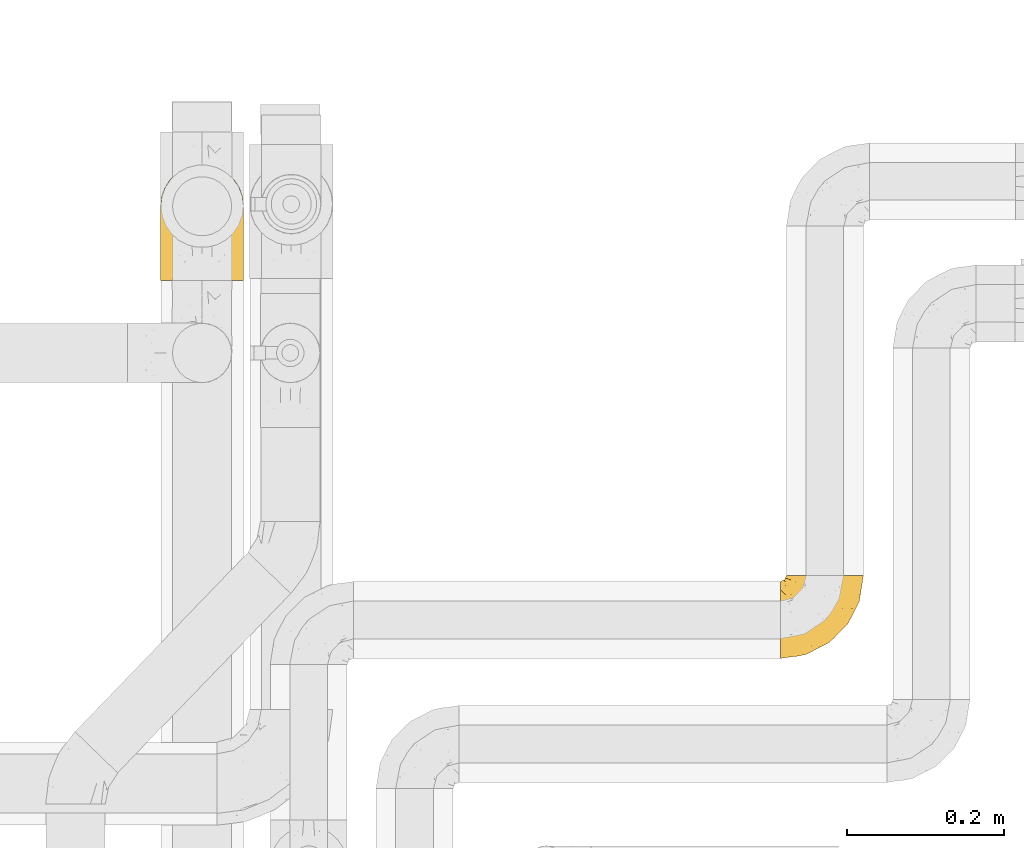
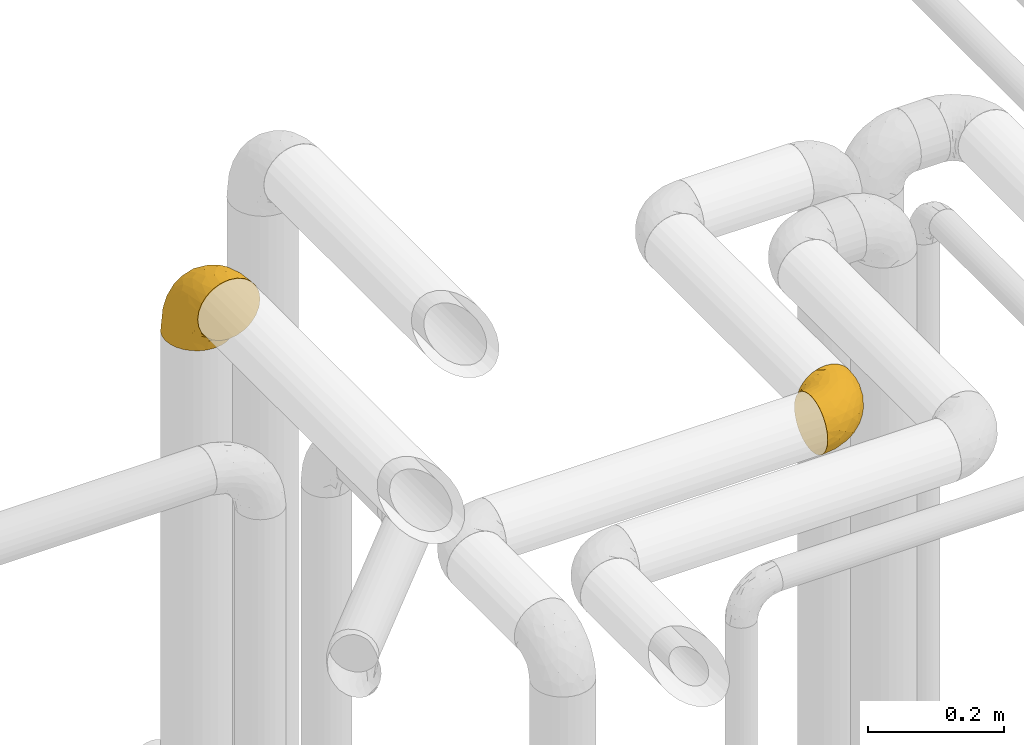
# One storey, part 397 of 827: 2 coverings.
"""IFC2X3 building model written with IfcOpenShell, lengths in millimetres."""

import ifcopenshell
import ifcopenshell.guid

model = None  # the IFC model being written
_history = None  # IfcOwnerHistory: only IFC2X3 demands one
_inside = {}  # id of a spatial element -> (the spatial element, [elements in it])
_under = {}  # id of a project, library or spatial element -> (it, [spatial elements below it])
_declared = {}  # id of a project -> (the project, [libraries it declares])
_typed = {}  # id of a type object -> (the type object, [elements of that type])
_made_of = {}  # id of a material, layer set ... -> (it, [elements and type objects made of it])


def new_model(schema):
    """Start an empty IFC model of exactly this schema.

    Asked for "IFC4X3", IfcOpenShell would pick the latest addendum, in which some entities
    have other attributes; the version numbers below select the first issue.
    IFC2X3 requires an IfcOwnerHistory on every rooted entity: one is made here for all.
    """
    global model, _history
    if schema == "IFC4X3":
        model = ifcopenshell.file(schema_version=(4, 3, 0, 0))
    else:
        model = ifcopenshell.file(schema=schema)
    _inside.clear()
    _under.clear()
    _declared.clear()
    _typed.clear()
    _made_of.clear()
    _history = None
    if model.schema == "IFC2X3":
        org = make("IfcOrganization", Name="unknown")
        user = make(
            "IfcPersonAndOrganization",
            ThePerson=make("IfcPerson", FamilyName="unknown"),
            TheOrganization=org,
        )
        app = make(
            "IfcApplication",
            ApplicationDeveloper=org,
            Version="unknown",
            ApplicationFullName="unknown",
            ApplicationIdentifier="unknown",
        )
        _history = make(
            "IfcOwnerHistory",
            OwningUser=user,
            OwningApplication=app,
            ChangeAction="ADDED",
            CreationDate=0,
        )
    return model


def make(cls, **values):
    """One entity of the class cls with the attributes given. An attribute that is None is left unset."""
    return model.create_entity(
        cls, **{name: value for name, value in values.items() if value is not None}
    )


def entity(cls, *values):
    """Any entity or typed value of the class cls, its attributes in the order of the schema. None: left unset."""
    e = model.create_entity(cls)
    for i, value in enumerate(values):
        if value is not None:
            e[i] = value
    return e


def rooted(cls, **values):
    """An entity with a GlobalId (a new one), such as an element, a storey or a relation."""
    return make(cls, GlobalId=ifcopenshell.guid.new(), OwnerHistory=_history, **values)


def si_unit(unit_type, name, prefix=None):
    """IfcSIUnit, for example si_unit("LENGTHUNIT", "METRE", prefix="MILLI")."""
    return make("IfcSIUnit", UnitType=unit_type, Prefix=prefix, Name=name)


def converted_unit(unit_type, name, factor, base, dimensions=None, offset=None):
    """IfcConversionBasedUnit, such as the inch: factor (a typed value) times the base unit."""
    return make(
        "IfcConversionBasedUnit"
        if offset is None
        else "IfcConversionBasedUnitWithOffset",
        ConversionOffset=offset,
        Dimensions=None
        if dimensions is None
        else entity("IfcDimensionalExponents", *dimensions),
        UnitType=unit_type,
        Name=name,
        ConversionFactor=make(
            "IfcMeasureWithUnit", ValueComponent=factor, UnitComponent=base
        ),
    )


def derived_unit(unit_type, elements):
    """IfcDerivedUnit: a product of units, each with its exponent."""
    return make(
        "IfcDerivedUnit",
        Elements=[
            make("IfcDerivedUnitElement", Unit=unit, Exponent=power)
            for unit, power in elements
        ],
        UnitType=unit_type,
    )


def assignment(units):
    """IfcUnitAssignment: the units of a project."""
    return None if units is None else make("IfcUnitAssignment", Units=units)


def point(xyz):
    """IfcCartesianPoint."""
    return None if xyz is None else make("IfcCartesianPoint", Coordinates=xyz)


def direction(xyz):
    """IfcDirection."""
    return None if xyz is None else make("IfcDirection", DirectionRatios=xyz)


def frame(location, z_axis=None, x_axis=None):
    """IfcAxis2Placement3D, a coordinate frame: its origin and axes. An axis left out is left unset."""
    return make(
        "IfcAxis2Placement3D",
        Location=point(location),
        Axis=direction(z_axis),
        RefDirection=direction(x_axis),
    )


def origin():
    """The frame at (0, 0, 0) with its axes left unset."""
    return frame((0.0, 0.0, 0.0))


def place(relative_to, where):
    """IfcLocalPlacement: puts the frame where relative to a parent placement (None: the world)."""
    return make(
        "IfcLocalPlacement", PlacementRelTo=relative_to, RelativePlacement=where
    )


def context(
    kind, dimensions, precision=None, world=None, true_north=None, identifier=None
):
    """IfcGeometricRepresentationContext, for example the 3D "Model" context."""
    return make(
        "IfcGeometricRepresentationContext",
        ContextIdentifier=identifier,
        ContextType=kind,
        CoordinateSpaceDimension=dimensions,
        Precision=precision,
        WorldCoordinateSystem=world,
        TrueNorth=true_north,
    )


def subcontext(parent, identifier, kind, view, scale=None):
    """IfcGeometricRepresentationSubContext, for example "Body" below "Model"."""
    return make(
        "IfcGeometricRepresentationSubContext",
        ContextIdentifier=identifier,
        ContextType=kind,
        ParentContext=parent,
        TargetScale=scale,
        TargetView=view,
    )


def project(units=None, contexts=None):
    """IfcProject with its units and contexts."""
    return rooted(
        "IfcProject",
        Name="project",
        RepresentationContexts=contexts,
        UnitsInContext=assignment(units),
    )


def spatial(cls, under=None, at=None, **own):
    """A site, building, storey or space (cls), placed at a placement, below another one or the project."""
    s = rooted(cls, ObjectPlacement=at, **own)
    if under is not None:
        _under.setdefault(under.id(), (under, []))[1].append(s)
    return s


def faces_of(points, faces, orient=None, outer=None):
    """IfcFace entities. A face is a list of loops; a loop is a list of indices into points, from 0.

    orient and outer hold one flag for each loop. By default every Orientation is true, the
    first loop of a face is its IfcFaceOuterBound and the others are IfcFaceBound.
    """
    made = []
    for i, loops in enumerate(faces):
        bounds = []
        for j, loop in enumerate(loops):
            is_outer = j == 0 if outer is None else outer[i][j]
            bounds.append(
                make(
                    "IfcFaceOuterBound" if is_outer else "IfcFaceBound",
                    Bound=make("IfcPolyLoop", Polygon=[points[k] for k in loop]),
                    Orientation=True if orient is None else orient[i][j],
                )
            )
        made.append(make("IfcFace", Bounds=bounds))
    return made


def faceted_brep(points, faces, orient=None, outer=None, voids=None):
    """IfcFacetedBrep: a solid bounded by flat faces; with voids (closed shells), ...WithVoids."""
    shared = [point(p) for p in points]
    hull = make("IfcClosedShell", CfsFaces=faces_of(shared, faces, orient, outer))
    if voids is None:
        return make("IfcFacetedBrep", Outer=hull)
    return make(
        "IfcFacetedBrepWithVoids",
        Outer=hull,
        Voids=[
            make(cls, CfsFaces=faces_of(shared, fs, o, b)) for cls, fs, o, b in voids
        ],
    )


def shape(context_of_items, identifier, shape_type, items):
    """IfcShapeRepresentation: the items that make up one representation, for example the "Body"."""
    return make(
        "IfcShapeRepresentation",
        ContextOfItems=context_of_items,
        RepresentationIdentifier=identifier,
        RepresentationType=shape_type,
        Items=items,
    )


def made_of(thing, what):
    """Note that an element or type object is made of a material, layer set ...; save() writes the relation."""
    if what is not None:
        _made_of.setdefault(what.id(), (what, []))[1].append(thing)
    return thing


def element(
    cls,
    number,
    at=None,
    inside=None,
    cuts=None,
    type_object=None,
    material=None,
    context=None,
    identifier="Body",
    shape_type=None,
    held_by="IfcProductDefinitionShape",
    body=None,
    shapes=None,
    **own,
):
    """One element of the class cls, such as IfcWall. Its Tag is "e" and its number.

    at: its placement. inside: the storey or other place that contains it. cuts: it is an
    opening in that element (IfcRelVoidsElement). A single representation is given by context,
    identifier, shape_type and body (its items); several are given by shapes. held_by: the class
    of the entity that holds the representations. save() writes the other relations.
    """
    e = rooted(cls, Tag="e%d" % number, ObjectPlacement=at, **own)
    if body is not None:
        shapes = [shape(context, identifier, shape_type, body)]
    if shapes is not None:
        e.Representation = make(held_by, Representations=shapes)
    if inside is not None:
        _inside.setdefault(inside.id(), (inside, []))[1].append(e)
    if cuts is not None:
        rooted(
            "IfcRelVoidsElement", RelatingBuildingElement=cuts, RelatedOpeningElement=e
        )
    if type_object is not None:
        _typed.setdefault(type_object.id(), (type_object, []))[1].append(e)
    return made_of(e, material)


def aggregate(whole, parts):
    """IfcRelAggregates: a whole, such as a stair, and the parts it consists of."""
    return rooted("IfcRelAggregates", RelatingObject=whole, RelatedObjects=parts)


def save(model, path):
    """Write the relations noted so far, then the file.

    IfcRelAggregates (storeys below a building ...), IfcRelContainedInSpatialStructure (elements
    in a storey), IfcRelDefinesByType, IfcRelAssociatesMaterial and IfcRelDeclares: one each for
    every whole, place, type object, material and project.
    """
    for whole, parts in _under.values():
        aggregate(whole, parts)
    for where, things in _inside.values():
        rooted(
            "IfcRelContainedInSpatialStructure",
            RelatedElements=things,
            RelatingStructure=where,
        )
    for kind, things in _typed.values():
        rooted("IfcRelDefinesByType", RelatedObjects=things, RelatingType=kind)
    for what, things in _made_of.values():
        rooted("IfcRelAssociatesMaterial", RelatedObjects=things, RelatingMaterial=what)
    for by, libraries in _declared.values():
        rooted("IfcRelDeclares", RelatingContext=by, RelatedDefinitions=libraries)
    model.write(path)


model = new_model("IFC2X3")

# Units and contexts
model_context = context("Model", 3, precision=0.01, world=origin(), true_north=direction((6.12303176911189e-17, 1.0)))
body_context = subcontext(model_context, "Body", "Model", "MODEL_VIEW")
ifc_project = project(units=[si_unit("LENGTHUNIT", "METRE", prefix="MILLI"), si_unit("AREAUNIT", "SQUARE_METRE"), si_unit("VOLUMEUNIT", "CUBIC_METRE"), converted_unit("PLANEANGLEUNIT", "DEGREE", entity("IfcRatioMeasure", 0.0174532925199433), si_unit("PLANEANGLEUNIT", "RADIAN"), dimensions=[0, 0, 0, 0, 0, 0, 0]), si_unit("MASSUNIT", "GRAM", prefix="KILO"), derived_unit("MASSDENSITYUNIT", [(si_unit("MASSUNIT", "GRAM", prefix="KILO"), 1), (si_unit("LENGTHUNIT", "METRE"), -3)]), derived_unit("MOMENTOFINERTIAUNIT", [(si_unit("LENGTHUNIT", "METRE"), 4)]), si_unit("TIMEUNIT", "SECOND"), si_unit("FREQUENCYUNIT", "HERTZ"), si_unit("THERMODYNAMICTEMPERATUREUNIT", "DEGREE_CELSIUS"), derived_unit("THERMALTRANSMITTANCEUNIT", [(si_unit("MASSUNIT", "GRAM", prefix="KILO"), 1), (si_unit("THERMODYNAMICTEMPERATUREUNIT", "KELVIN"), -1), (si_unit("TIMEUNIT", "SECOND"), -3)]), derived_unit("VOLUMETRICFLOWRATEUNIT", [(si_unit("LENGTHUNIT", "METRE"), 3), (si_unit("TIMEUNIT", "SECOND"), -1)]), derived_unit("MASSFLOWRATEUNIT", [(si_unit("MASSUNIT", "GRAM", prefix="KILO"), 1), (si_unit("TIMEUNIT", "SECOND"), -1)]), derived_unit("ROTATIONALFREQUENCYUNIT", [(si_unit("TIMEUNIT", "SECOND"), -1)]), si_unit("ELECTRICCURRENTUNIT", "AMPERE"), si_unit("ELECTRICVOLTAGEUNIT", "VOLT"), si_unit("POWERUNIT", "WATT"), si_unit("FORCEUNIT", "NEWTON", prefix="KILO"), si_unit("ILLUMINANCEUNIT", "LUX"), si_unit("LUMINOUSFLUXUNIT", "LUMEN"), si_unit("LUMINOUSINTENSITYUNIT", "CANDELA"), derived_unit("USERDEFINED", [(si_unit("MASSUNIT", "GRAM", prefix="KILO"), -1), (si_unit("LENGTHUNIT", "METRE"), -2), (si_unit("TIMEUNIT", "SECOND"), 3), (si_unit("LUMINOUSFLUXUNIT", "LUMEN"), 1)]), derived_unit("LINEARVELOCITYUNIT", [(si_unit("LENGTHUNIT", "METRE"), 1), (si_unit("TIMEUNIT", "SECOND"), -1)]), si_unit("PRESSUREUNIT", "PASCAL"), derived_unit("USERDEFINED", [(si_unit("LENGTHUNIT", "METRE"), -2), (si_unit("MASSUNIT", "GRAM", prefix="KILO"), 1), (si_unit("TIMEUNIT", "SECOND"), -2)]), derived_unit("LINEARFORCEUNIT", [(si_unit("MASSUNIT", "GRAM", prefix="KILO"), 1), (si_unit("LENGTHUNIT", "METRE"), 1), (si_unit("TIMEUNIT", "SECOND"), -2), (si_unit("LENGTHUNIT", "METRE"), -1)]), derived_unit("PLANARFORCEUNIT", [(si_unit("MASSUNIT", "GRAM", prefix="KILO"), 1), (si_unit("LENGTHUNIT", "METRE"), 1), (si_unit("TIMEUNIT", "SECOND"), -2), (si_unit("LENGTHUNIT", "METRE"), -2)])], contexts=[model_context])

# Site, building, storey
site_placement = place(None, origin())
site = spatial("IfcSite", under=ifc_project, at=site_placement, CompositionType="ELEMENT")
building_placement = place(site_placement, origin())
building = spatial("IfcBuilding", under=site, at=building_placement, CompositionType="ELEMENT")
storey_placement = place(building_placement, frame((0.0, 0.0, 28200.0)))
storey = spatial("IfcBuildingStorey", under=building, at=storey_placement, Name="08", CompositionType="ELEMENT", Elevation=28200.0)

# Coverings
covering_1_placement = place(storey_placement, frame((47293.4, 14696.28, 2949.25)))
element("IfcCovering", 1, at=covering_1_placement, inside=storey, Name=":ADSK_", ObjectType=":ADSK_", PredefinedType="INSULATION", context=body_context, shape_type="Brep", body=[
    faceted_brep([(58.6, 107.75, 99.9), (69.54, 107.75, 98.66), (79.93, 107.75, 95.02), (89.25, 107.75, 89.17), (97.03, 107.75, 81.38), (102.88, 107.75, 72.06), (106.51, 107.75, 61.68), (107.75, 107.75, 50.75), (106.51, 107.75, 39.8), (102.87, 107.75, 29.41), (97.02, 107.75, 20.09), (89.23, 107.75, 12.31), (79.91, 107.75, 6.46), (69.53, 107.75, 2.83), (58.6, 107.75, 1.6), (52.89, 107.75, 2.24), (47.65, 107.75, 2.83), (42.46, 107.75, 4.65), (37.26, 107.75, 6.47), (27.94, 107.75, 12.32), (20.16, 107.75, 20.11), (14.31, 107.75, 29.43), (10.68, 107.75, 39.81), (9.45, 107.75, 50.75), (10.68, 107.75, 61.69), (14.32, 107.75, 72.08), (20.17, 107.75, 81.4), (27.96, 107.75, 89.18), (37.28, 107.75, 95.03), (42.47, 107.75, 96.85), (47.66, 107.75, 98.66), (52.89, 107.75, 99.25), (55.75, 107.75, 99.57), (1.6, 98.22, 38.02), (1.6, 93.31, 26.17), (1.6, 89.4, 21.08), (1.6, 85.5, 15.99), (1.6, 80.41, 12.09), (1.6, 75.32, 8.18), (1.6, 69.39, 5.73), (1.6, 63.47, 3.27), (1.6, 56.48, 2.35), (1.6, 53.61, 1.97), (1.6, 50.75, 1.6), (1.6, 38.02, 3.27), (1.6, 26.17, 8.18), (1.6, 15.99, 15.99), (1.6, 8.18, 26.17), (1.6, 3.27, 38.02), (1.6, 1.6, 50.75), (1.6, 3.27, 63.47), (1.6, 8.18, 75.32), (1.6, 15.99, 85.5), (1.6, 26.17, 93.31), (1.6, 38.02, 98.22), (1.6, 50.75, 99.9), (1.6, 56.48, 99.14), (1.6, 63.47, 98.22), (1.6, 69.39, 95.77), (1.6, 75.32, 93.31), (1.6, 80.41, 89.4), (1.6, 85.5, 85.5), (1.6, 89.4, 80.41), (1.6, 93.31, 75.32), (1.6, 98.22, 63.47), (1.6, 99.9, 50.75), (69.96, 27.53, 59.31), (59.59, 25.32, 73.08), (51.96, 16.29, 63.72), (34.4, 6.79, 50.75), (23.37, 4.51, 58.64), (13.68, 3.51, 50.75), (41.52, 17.47, 76.74), (26.26, 7.6, 67.68), (20.18, 12.27, 78.92), (72.33, 70.89, 94.31), (65.88, 87.17, 98.76), (57.55, 67.3, 98.4), (23.76, 31.65, 94.57), (46.5, 33.58, 89.91), (46.57, 47.23, 96.32), (21.17, 43.26, 98.79), (23.41, 55.08, 99.9), (17.92, 53.99, 99.9), (12.43, 52.9, 99.9), (9.72, 52.36, 99.9), (7.01, 51.82, 99.9), (26.77, 21.5, 87.31), (76.59, 89.94, 95.61), (95.55, 60.45, 60.43), (102.57, 83.0, 65.24), (92.89, 64.79, 72.87), (54.26, 85.93, 99.9), (51.17, 81.31, 99.9), (48.08, 76.69, 99.9), (44.99, 72.06, 99.9), (41.9, 67.44, 99.9), (85.16, 88.74, 90.65), (85.97, 45.98, 63.14), (59.58, 47.13, 91.89), (99.5, 89.4, 75.25), (105.83, 95.66, 50.75), (53.59, 28.5, 82.18), (67.0, 42.81, 85.08), (71.56, 38.28, 76.93), (87.47, 45.35, 50.75), (75.73, 33.61, 50.75), (92.24, 82.57, 83.02), (58.06, 105.04, 99.9), (57.52, 102.33, 99.9), (56.44, 96.91, 99.9), (55.35, 91.42, 99.9), (81.33, 65.92, 87.13), (80.35, 53.11, 80.85), (39.44, 54.37, 99.17), (102.55, 74.94, 50.75), (37.28, 64.35, 99.9), (32.65, 61.26, 99.9), (28.03, 58.17, 99.9), (63.99, 21.87, 50.75), (74.55, 34.79, 67.61), (83.62, 48.48, 72.25), (95.01, 60.15, 50.75), (49.19, 14.33, 50.75), (46.96, 99.07, 98.69), (8.77, 60.55, 99.01), (18.28, 64.18, 98.79), (11.68, 64.36, 98.29), (11.79, 103.17, 68.51), (15.69, 101.69, 76.82), (42.49, 87.75, 98.54), (47.41, 89.38, 99.3), (7.94, 88.34, 83.57), (9.27, 82.14, 89.47), (7.98, 94.51, 75.76), (13.4, 89.64, 84.86), (13.04, 98.41, 75.89), (7.36, 99.71, 64.77), (23.46, 89.37, 90.83), (30.46, 88.21, 94.62), (26.54, 95.2, 90.37), (6.76, 79.14, 91.18), (26.46, 101.22, 88.65), (20.77, 99.41, 84.11), (20.68, 84.72, 91.75), (40.26, 97.47, 96.86), (7.15, 102.19, 50.75), (9.28, 104.02, 58.97), (38.78, 82.66, 98.37), (18.27, 95.42, 83.91), (31.78, 78.67, 97.52), (12.75, 72.69, 95.55), (22.96, 66.46, 98.76), (17.55, 75.3, 95.26), (27.63, 72.74, 98.04), (15.23, 82.93, 90.65), (33.25, 99.27, 93.51), (32.43, 93.51, 94.16), (27.9, 67.35, 99.1), (7.97, 94.51, 25.73), (15.22, 82.94, 10.84), (7.93, 88.33, 17.92), (13.38, 89.64, 16.64), (13.12, 103.62, 30.44), (42.49, 87.74, 2.95), (47.4, 89.38, 2.19), (51.17, 81.31, 1.6), (40.24, 97.47, 4.63), (20.76, 99.41, 17.39), (12.43, 52.9, 1.6), (7.01, 51.82, 1.6), (4.31, 51.28, 1.6), (26.44, 101.21, 12.86), (26.52, 95.19, 11.13), (11.68, 64.36, 3.2), (12.75, 72.69, 5.94), (9.27, 82.13, 12.02), (17.55, 75.3, 6.23), (6.76, 79.14, 10.31), (33.21, 99.28, 8.0), (32.41, 93.51, 7.34), (8.77, 60.55, 2.48), (22.96, 66.46, 2.73), (18.48, 63.96, 2.64), (56.44, 96.91, 1.6), (46.95, 99.06, 2.8), (7.36, 99.7, 36.71), (17.92, 53.99, 1.6), (23.41, 55.08, 1.6), (9.85, 103.3, 38.59), (57.52, 102.33, 1.6), (56.98, 99.62, 1.6), (48.08, 76.69, 1.6), (38.78, 82.66, 3.12), (18.25, 95.42, 17.59), (44.99, 72.06, 1.6), (31.74, 78.68, 3.98), (30.45, 88.2, 6.87), (27.63, 72.75, 3.45), (20.65, 84.74, 9.76), (55.35, 91.42, 1.6), (54.26, 85.93, 1.6), (13.03, 98.41, 25.62), (23.44, 89.37, 10.67), (27.9, 67.35, 2.39), (32.65, 61.26, 1.6), (28.03, 58.17, 1.6), (37.28, 64.35, 1.6), (41.9, 67.44, 1.6), (39.74, 54.08, 2.4), (23.37, 4.51, 42.85), (26.77, 21.5, 14.18), (46.18, 33.43, 11.56), (53.54, 28.5, 19.27), (41.53, 17.47, 24.75), (59.61, 25.36, 28.37), (76.79, 90.18, 5.95), (66.11, 86.97, 2.79), (21.17, 43.26, 2.71), (51.96, 16.29, 37.78), (26.26, 7.6, 33.81), (20.18, 12.27, 22.57), (23.76, 31.65, 6.92), (92.88, 64.79, 28.61), (102.57, 83.0, 36.24), (95.54, 60.44, 41.05), (71.63, 38.35, 24.55), (74.55, 34.8, 33.88), (72.51, 71.54, 7.11), (69.96, 27.53, 42.18), (92.23, 82.57, 18.46), (85.15, 88.74, 10.84), (80.45, 53.19, 20.69), (83.65, 48.49, 29.27), (57.57, 67.28, 3.1), (63.68, 52.32, 9.18), (85.95, 45.94, 38.38), (99.49, 89.4, 26.23), (81.23, 65.75, 14.34), (47.07, 46.73, 5.46), (66.99, 42.82, 16.39)], [[[0, 1, 2, 3, 4, 5, 6, 7, 8, 9, 10, 11, 12, 13, 14, 15, 16, 17, 18, 19, 20, 21, 22, 23, 24, 25, 26, 27, 28, 29, 30, 31, 32]], [[33, 34, 35, 36, 37, 38, 39, 40, 41, 42, 43, 44, 45, 46, 47, 48, 49, 50, 51, 52, 53, 54, 55, 56, 57, 58, 59, 60, 61, 62, 63, 64, 65]], [[66, 67, 68]], [[69, 70, 71]], [[68, 72, 73]], [[73, 72, 74]], [[75, 76, 77]], [[78, 79, 80]], [[51, 50, 73]], [[81, 82, 83, 84, 85, 86, 55]], [[52, 87, 53]], [[74, 52, 51]], [[2, 1, 88]], [[89, 90, 91]], [[77, 92, 93, 94, 95, 96]], [[55, 54, 81]], [[78, 53, 87]], [[5, 90, 6]], [[88, 76, 75]], [[97, 3, 2]], [[89, 91, 98]], [[99, 80, 79]], [[90, 5, 100]], [[74, 87, 52]], [[100, 5, 4]], [[90, 101, 6]], [[79, 102, 103]], [[102, 67, 104]], [[105, 98, 106]], [[107, 4, 3]], [[76, 0, 108, 109, 110, 111, 92]], [[107, 112, 113]], [[114, 77, 96]], [[89, 115, 90]], [[114, 96, 116, 117, 118, 82]], [[75, 97, 88]], [[119, 66, 68]], [[50, 71, 70]], [[100, 91, 90]], [[99, 77, 80]], [[102, 104, 103]], [[97, 107, 3]], [[80, 81, 78]], [[107, 97, 112]], [[68, 73, 70]], [[66, 98, 120]], [[78, 81, 54]], [[114, 81, 80]], [[53, 78, 54]], [[78, 87, 79]], [[102, 87, 72]], [[79, 103, 99]], [[4, 107, 100]], [[91, 100, 107]], [[88, 97, 2]], [[112, 97, 75]], [[99, 112, 75]], [[103, 104, 113]], [[91, 121, 98]], [[89, 105, 122, 115]], [[101, 90, 115]], [[101, 7, 6]], [[88, 1, 76]], [[0, 76, 1]], [[92, 77, 76]], [[73, 74, 51]], [[87, 74, 72]], [[81, 114, 82]], [[77, 114, 80]], [[87, 102, 79]], [[67, 102, 72]], [[68, 67, 72]], [[67, 120, 104]], [[120, 121, 104]], [[104, 121, 113]], [[121, 120, 98]], [[91, 107, 113]], [[91, 113, 121]], [[103, 113, 112]], [[106, 98, 66]], [[105, 89, 98]], [[106, 66, 119]], [[67, 66, 120]], [[68, 69, 123, 119]], [[50, 49, 71]], [[50, 70, 73]], [[112, 99, 103]], [[77, 99, 75]], [[69, 68, 70]], [[29, 124, 110]], [[84, 83, 125]], [[126, 82, 118]], [[59, 58, 127]], [[25, 128, 129]], [[130, 93, 131]], [[132, 62, 133]], [[134, 135, 136]], [[137, 65, 64]], [[64, 134, 137]], [[138, 139, 140]], [[111, 110, 124, 92]], [[134, 136, 137]], [[134, 64, 63]], [[141, 61, 60]], [[125, 58, 57]], [[142, 143, 140]], [[142, 26, 143]], [[127, 83, 82]], [[28, 124, 29]], [[108, 0, 32, 31, 30, 110, 109]], [[30, 29, 110]], [[135, 144, 138]], [[28, 145, 124]], [[57, 56, 55, 86, 85, 84]], [[146, 147, 23]], [[24, 23, 147]], [[25, 143, 26]], [[95, 94, 148]], [[24, 128, 25]], [[149, 138, 143]], [[124, 145, 131]], [[127, 58, 125]], [[150, 148, 139]], [[127, 126, 151]], [[151, 59, 127]], [[152, 151, 126]], [[153, 154, 155]], [[153, 133, 141]], [[145, 28, 27]], [[142, 156, 27]], [[157, 148, 130]], [[61, 133, 62]], [[134, 132, 135]], [[147, 128, 24]], [[65, 137, 146]], [[146, 137, 147]], [[128, 137, 136]], [[137, 128, 147]], [[128, 136, 129]], [[149, 129, 136]], [[25, 129, 143]], [[158, 152, 117]], [[152, 118, 117]], [[153, 151, 152]], [[158, 116, 154]], [[144, 150, 138]], [[153, 152, 158]], [[133, 153, 155]], [[133, 155, 132]], [[60, 151, 141]], [[135, 132, 155]], [[134, 63, 132]], [[144, 135, 155]], [[135, 138, 149]], [[155, 154, 144]], [[150, 154, 96]], [[154, 150, 144]], [[148, 94, 130]], [[82, 126, 127]], [[118, 152, 126]], [[150, 96, 95]], [[139, 148, 157]], [[150, 95, 148]], [[93, 92, 131]], [[130, 145, 156]], [[130, 94, 93]], [[84, 125, 57]], [[127, 125, 83]], [[140, 139, 157]], [[150, 139, 138]], [[140, 157, 142]], [[138, 140, 143]], [[156, 142, 157]], [[27, 26, 142]], [[130, 156, 157]], [[145, 27, 156]], [[132, 63, 62]], [[124, 131, 92]], [[130, 131, 145]], [[129, 149, 143]], [[135, 149, 136]], [[141, 133, 61]], [[60, 59, 151]], [[141, 151, 153]], [[116, 96, 154]], [[153, 158, 154]], [[158, 117, 116]], [[34, 33, 159]], [[160, 161, 162]], [[22, 21, 163]], [[164, 165, 166]], [[19, 18, 167]], [[168, 21, 20]], [[42, 41, 40, 169, 170, 171, 43]], [[172, 173, 168]], [[174, 38, 175]], [[176, 177, 178]], [[179, 164, 180]], [[40, 181, 169]], [[182, 183, 175]], [[17, 184, 185]], [[65, 146, 186]], [[187, 174, 188]], [[23, 22, 189]], [[174, 39, 38]], [[15, 14, 190, 191, 184, 16]], [[181, 40, 39]], [[192, 193, 164]], [[194, 163, 168]], [[33, 186, 159]], [[180, 173, 172]], [[195, 196, 193]], [[18, 185, 167]], [[173, 180, 197]], [[198, 199, 196]], [[200, 201, 185, 184]], [[184, 17, 16]], [[18, 17, 185]], [[202, 159, 186]], [[194, 168, 203]], [[189, 163, 202]], [[204, 205, 182]], [[187, 181, 174]], [[160, 177, 176]], [[206, 183, 182]], [[206, 182, 205]], [[201, 165, 185]], [[165, 164, 167]], [[172, 179, 180]], [[202, 194, 162]], [[176, 161, 160]], [[65, 186, 33]], [[163, 189, 22]], [[175, 177, 182]], [[174, 183, 188]], [[177, 198, 204]], [[199, 160, 162]], [[198, 207, 204]], [[175, 38, 37]], [[198, 177, 160]], [[178, 177, 175]], [[176, 35, 161]], [[34, 159, 161]], [[162, 161, 159]], [[202, 162, 159]], [[199, 162, 203]], [[196, 199, 203]], [[198, 160, 199]], [[193, 197, 180]], [[208, 198, 196]], [[188, 183, 206]], [[175, 183, 174]], [[193, 192, 195]], [[195, 208, 196]], [[197, 196, 203]], [[180, 164, 193]], [[168, 163, 21]], [[166, 165, 201]], [[166, 192, 164]], [[189, 202, 186]], [[186, 146, 189]], [[23, 189, 146]], [[174, 181, 39]], [[169, 181, 187]], [[196, 197, 193]], [[173, 203, 168]], [[203, 173, 197]], [[172, 168, 20]], [[20, 19, 172]], [[179, 172, 19]], [[19, 167, 179]], [[164, 179, 167]], [[35, 176, 36]], [[35, 34, 161]], [[185, 165, 167]], [[162, 194, 203]], [[163, 194, 202]], [[176, 178, 36]], [[37, 36, 178]], [[175, 37, 178]], [[177, 204, 182]], [[207, 198, 208]], [[207, 205, 204]], [[209, 188, 206, 205, 207, 208]], [[48, 210, 71]], [[211, 212, 213]], [[214, 213, 215]], [[216, 217, 13]], [[218, 43, 171, 170, 169, 187, 188]], [[219, 220, 214]], [[47, 46, 221]], [[210, 48, 220]], [[211, 222, 212]], [[222, 45, 44]], [[221, 220, 47]], [[47, 220, 48]], [[221, 211, 214]], [[223, 224, 225]], [[211, 46, 45]], [[226, 227, 215]], [[43, 218, 44]], [[217, 216, 228]], [[219, 215, 229]], [[14, 13, 217]], [[224, 9, 8]], [[10, 230, 11]], [[11, 231, 12]], [[232, 223, 233]], [[234, 208, 195, 192, 166, 201]], [[235, 234, 228]], [[222, 44, 218]], [[106, 229, 236]], [[224, 237, 9]], [[231, 238, 228]], [[9, 237, 10]], [[115, 224, 101]], [[239, 234, 235]], [[231, 11, 230]], [[223, 230, 237]], [[224, 8, 101]], [[223, 236, 233]], [[225, 115, 122, 105]], [[216, 12, 231]], [[209, 234, 239]], [[210, 219, 69]], [[219, 214, 215]], [[229, 119, 219]], [[209, 218, 188]], [[239, 212, 222]], [[239, 222, 218]], [[45, 222, 211]], [[235, 212, 239]], [[213, 212, 240]], [[223, 237, 224]], [[230, 10, 237]], [[238, 231, 230]], [[216, 231, 228]], [[232, 230, 223]], [[235, 238, 240]], [[115, 225, 224]], [[233, 236, 227]], [[8, 7, 101]], [[234, 209, 208]], [[218, 209, 239]], [[217, 228, 234]], [[13, 12, 216]], [[234, 201, 217]], [[217, 201, 200, 184, 191, 190, 14]], [[211, 221, 46]], [[220, 221, 214]], [[71, 210, 69]], [[71, 49, 48]], [[219, 210, 220]], [[226, 215, 213]], [[211, 213, 214]], [[226, 213, 240]], [[215, 227, 229]], [[232, 240, 238]], [[233, 227, 226]], [[232, 233, 226]], [[236, 223, 225]], [[240, 232, 226]], [[232, 238, 230]], [[225, 105, 236]], [[236, 105, 106]], [[236, 229, 227]], [[123, 69, 219, 119]], [[106, 119, 229]], [[238, 235, 228]], [[212, 235, 240]]]),
])
covering_2_placement = place(storey_placement, frame((46502.13, 15178.77, 3103.45)))
element("IfcCovering", 2, at=covering_2_placement, inside=storey, Name=":ADSK_", ObjectType=":ADSK_", PredefinedType="INSULATION", context=body_context, shape_type="Brep", body=[
    faceted_brep([(42.85, 148.32, 1.6), (54.65, 149.65, 1.6), (66.46, 148.31, 1.6), (77.67, 144.39, 1.6), (87.73, 138.06, 1.6), (96.13, 129.66, 1.6), (102.45, 119.6, 1.6), (106.37, 108.39, 1.6), (107.7, 96.6, 1.6), (106.36, 84.79, 1.6), (102.44, 73.57, 1.6), (96.11, 63.51, 1.6), (87.71, 55.11, 1.6), (77.65, 48.79, 1.6), (66.44, 44.87, 1.6), (54.65, 43.55, 1.6), (42.84, 44.88, 1.6), (31.62, 48.8, 1.6), (21.56, 55.13, 1.6), (13.16, 63.53, 1.6), (6.84, 73.59, 1.6), (2.92, 84.8, 1.6), (1.6, 96.6, 1.6), (2.93, 108.41, 1.6), (6.85, 119.62, 1.6), (13.18, 129.68, 1.6), (21.58, 138.08, 1.6), (31.64, 144.4, 1.6), (68.38, 1.6, 45.35), (81.17, 1.6, 50.65), (92.16, 1.6, 59.08), (100.59, 1.6, 70.07), (105.89, 1.6, 82.86), (107.7, 1.6, 96.6), (105.89, 1.6, 110.33), (100.59, 1.6, 123.12), (92.16, 1.6, 134.11), (81.17, 1.6, 142.54), (68.38, 1.6, 147.84), (54.65, 1.6, 149.65), (40.91, 1.6, 147.84), (28.12, 1.6, 142.54), (17.13, 1.6, 134.11), (8.7, 1.6, 123.12), (3.4, 1.6, 110.33), (1.6, 1.6, 96.6), (3.4, 1.6, 82.86), (8.7, 1.6, 70.07), (17.13, 1.6, 59.08), (28.12, 1.6, 50.65), (40.91, 1.6, 45.35), (54.65, 1.6, 43.55), (23.76, 27.97, 137.19), (35.87, 37.09, 141.79), (25.52, 58.27, 128.89), (45.07, 27.13, 146.54), (54.65, 39.91, 144.6), (12.57, 109.11, 69.77), (15.93, 94.41, 94.41), (24.82, 110.94, 87.22), (37.92, 89.69, 117.2), (54.65, 75.62, 129.81), (54.65, 106.28, 106.28), (5.82, 60.12, 101.45), (8.38, 41.41, 115.81), (10.19, 63.22, 109.14), (3.86, 32.05, 107.65), (2.5, 52.13, 93.36), (19.48, 123.27, 59.44), (29.7, 129.32, 63.23), (28.0, 138.3, 35.59), (35.28, 62.95, 132.3), (45.15, 55.89, 138.41), (14.54, 37.4, 126.28), (54.65, 144.6, 39.91), (38.55, 142.66, 37.44), (40.99, 117.85, 90.35), (43.24, 134.01, 65.0), (8.56, 89.25, 85.4), (2.51, 103.34, 26.66), (5.69, 113.52, 29.88), (1.6, 57.43, 78.45), (1.6, 44.19, 85.2), (1.6, 30.95, 91.95), (3.22, 77.98, 77.98), (18.7, 132.66, 29.55), (11.86, 121.52, 41.42), (24.78, 86.93, 111.13), (15.99, 68.4, 114.67), (1.6, 78.45, 57.43), (1.6, 67.94, 67.94), (1.6, 94.53, 14.64), (1.6, 91.95, 30.95), (2.5, 93.36, 52.13), (1.6, 85.2, 44.19), (5.82, 101.45, 60.12), (54.65, 129.81, 75.62), (1.6, 16.27, 94.27), (32.3, 42.46, 24.59), (25.01, 40.4, 34.69), (18.18, 49.71, 31.15), (3.03, 39.4, 75.18), (6.69, 31.26, 67.55), (3.21, 27.7, 79.36), (2.73, 16.7, 84.32), (3.93, 70.67, 40.81), (2.55, 81.69, 29.93), (7.7, 16.68, 70.24), (54.65, 22.57, 37.93), (54.65, 14.26, 40.15), (41.58, 17.68, 42.1), (17.93, 19.58, 55.38), (14.97, 33.49, 52.17), (22.2, 33.01, 44.32), (43.45, 40.69, 19.85), (54.65, 40.15, 14.26), (54.65, 37.93, 22.57), (40.37, 31.04, 34.17), (8.47, 45.29, 54.85), (29.46, 23.55, 44.63), (32.17, 11.36, 47.52), (3.39, 59.1, 59.1), (7.76, 57.42, 44.11), (2.57, 68.96, 53.21), (11.54, 20.38, 62.86), (6.21, 72.46, 20.58), (2.9, 83.66, 15.79), (11.19, 60.66, 27.67), (14.27, 61.01, 13.49), (22.4, 51.85, 18.04), (34.87, 46.07, 12.44), (54.65, 30.25, 30.25), (4.01, 46.65, 66.71), (16.42, 43.0, 42.52), (91.36, 19.58, 55.38), (103.07, 72.44, 20.57), (67.71, 17.67, 42.11), (107.7, 78.45, 57.43), (106.72, 68.97, 53.22), (105.35, 70.65, 40.81), (65.83, 40.69, 19.85), (76.97, 42.45, 24.58), (68.91, 31.04, 34.16), (92.85, 42.99, 42.5), (100.82, 45.18, 54.93), (94.28, 33.46, 52.13), (98.08, 60.64, 27.66), (101.51, 57.37, 44.12), (107.7, 57.43, 78.45), (107.7, 44.19, 85.2), (106.25, 39.35, 75.17), (107.7, 16.27, 94.27), (106.56, 16.7, 84.32), (107.7, 91.95, 30.95), (107.7, 85.2, 44.19), (106.74, 81.68, 29.98), (105.31, 46.68, 66.78), (102.6, 31.26, 67.55), (101.59, 16.68, 70.24), (106.08, 27.7, 79.36), (95.01, 60.99, 13.48), (86.87, 51.84, 18.03), (84.27, 40.41, 34.66), (91.11, 49.72, 31.14), (74.4, 46.06, 12.43), (107.7, 94.53, 14.64), (77.12, 11.35, 47.52), (87.06, 33.02, 44.28), (106.38, 83.65, 15.8), (97.75, 20.38, 62.86), (107.7, 67.94, 67.94), (79.83, 23.53, 44.64), (105.91, 59.12, 59.12), (107.7, 30.95, 91.95), (83.77, 58.27, 128.89), (85.53, 27.97, 137.19), (94.75, 37.4, 126.28), (100.91, 41.41, 115.81), (64.22, 27.21, 146.53), (73.42, 37.09, 141.79), (64.15, 53.2, 139.45), (106.79, 52.13, 93.36), (106.79, 103.34, 26.67), (103.61, 113.5, 29.87), (103.47, 101.45, 60.12), (93.36, 94.41, 94.41), (96.75, 109.08, 69.76), (84.48, 110.95, 87.19), (106.79, 93.36, 52.13), (106.07, 77.98, 77.98), (105.43, 32.05, 107.65), (73.44, 64.63, 131.74), (89.82, 123.25, 59.44), (90.61, 132.65, 29.54), (79.61, 129.32, 63.2), (81.34, 139.96, 27.9), (68.3, 117.85, 90.35), (71.37, 89.69, 117.2), (97.44, 121.51, 41.39), (99.1, 63.23, 109.14), (100.74, 89.17, 85.46), (70.76, 142.66, 37.43), (93.3, 68.4, 114.67), (84.5, 86.94, 111.12), (103.47, 60.12, 101.45), (68.73, 133.2, 65.16)], [[[0, 1, 2, 3, 4, 5, 6, 7, 8, 9, 10, 11, 12, 13, 14, 15, 16, 17, 18, 19, 20, 21, 22, 23, 24, 25, 26, 27]], [[28, 29, 30, 31, 32, 33, 34, 35, 36, 37, 38, 39, 40, 41, 42, 43, 44, 45, 46, 47, 48, 49, 50, 51]], [[52, 53, 54]], [[55, 39, 56]], [[57, 58, 59]], [[60, 61, 62]], [[63, 64, 65]], [[66, 63, 67]], [[68, 69, 70]], [[53, 71, 54]], [[41, 40, 53]], [[53, 72, 71]], [[73, 42, 52]], [[42, 41, 52]], [[74, 0, 75]], [[69, 76, 77]], [[43, 73, 64]], [[45, 44, 66]], [[57, 78, 58]], [[23, 79, 80]], [[67, 81, 82, 83]], [[67, 84, 81]], [[24, 23, 80]], [[25, 85, 26]], [[86, 85, 25]], [[42, 73, 43]], [[0, 27, 75]], [[25, 24, 86]], [[70, 26, 85]], [[0, 74, 1]], [[68, 85, 86]], [[66, 64, 63]], [[60, 59, 87]], [[54, 87, 88]], [[76, 60, 62]], [[84, 89, 90, 81]], [[79, 22, 91, 92]], [[77, 74, 75]], [[93, 92, 94, 89]], [[80, 86, 24]], [[40, 55, 53]], [[76, 59, 60]], [[93, 84, 95]], [[76, 62, 96]], [[55, 72, 53]], [[70, 27, 26]], [[75, 70, 69]], [[78, 84, 63]], [[93, 79, 92]], [[95, 86, 80]], [[77, 76, 96]], [[59, 69, 68]], [[57, 68, 86]], [[68, 57, 59]], [[59, 58, 87]], [[76, 69, 59]], [[88, 87, 58]], [[87, 54, 71]], [[86, 95, 57]], [[78, 57, 95]], [[84, 78, 95]], [[78, 63, 65]], [[58, 78, 65]], [[54, 88, 73]], [[84, 93, 89]], [[79, 95, 80]], [[79, 93, 95]], [[22, 79, 23]], [[66, 83, 97, 45]], [[84, 67, 63]], [[83, 66, 67]], [[64, 44, 43]], [[64, 66, 44]], [[65, 73, 88]], [[53, 52, 41]], [[73, 52, 54]], [[73, 65, 64]], [[65, 88, 58]], [[39, 55, 40]], [[72, 55, 56]], [[56, 61, 72]], [[60, 72, 61]], [[72, 60, 71]], [[87, 71, 60]], [[27, 70, 75]], [[68, 70, 85]], [[74, 77, 96]], [[69, 77, 75]], [[98, 99, 100]], [[46, 45, 97]], [[101, 102, 103]], [[103, 104, 83]], [[105, 94, 106]], [[107, 103, 102]], [[108, 109, 51, 110]], [[111, 112, 113]], [[114, 115, 116]], [[47, 104, 107]], [[110, 117, 108]], [[49, 48, 111]], [[102, 118, 112]], [[119, 120, 111]], [[50, 49, 120]], [[121, 122, 118]], [[105, 123, 89]], [[124, 48, 107]], [[20, 19, 125]], [[121, 81, 90]], [[117, 119, 99]], [[21, 20, 126]], [[22, 21, 91]], [[105, 125, 127]], [[110, 51, 50]], [[19, 128, 125]], [[16, 15, 115]], [[129, 98, 100]], [[126, 91, 21]], [[128, 129, 127]], [[122, 123, 105]], [[114, 117, 98]], [[17, 16, 130]], [[18, 128, 19]], [[129, 18, 17]], [[125, 106, 126]], [[115, 114, 16]], [[130, 129, 17]], [[114, 98, 130]], [[117, 116, 131, 108]], [[99, 119, 113]], [[122, 121, 123]], [[92, 126, 106]], [[105, 127, 122]], [[132, 121, 118]], [[114, 130, 16]], [[129, 130, 98]], [[50, 120, 110]], [[129, 128, 18]], [[125, 128, 127]], [[125, 126, 20]], [[91, 126, 92]], [[105, 89, 94]], [[105, 106, 125]], [[94, 92, 106]], [[100, 122, 127]], [[118, 122, 133]], [[112, 118, 133]], [[132, 118, 102]], [[132, 102, 101]], [[81, 121, 132]], [[82, 103, 83]], [[132, 101, 81]], [[104, 47, 46]], [[124, 107, 102]], [[48, 47, 107]], [[113, 112, 133]], [[112, 111, 124]], [[99, 113, 133]], [[111, 113, 119]], [[99, 133, 100]], [[117, 99, 98]], [[122, 100, 133]], [[127, 129, 100]], [[103, 82, 101]], [[81, 101, 82]], [[112, 124, 102]], [[48, 124, 111]], [[104, 103, 107]], [[46, 97, 104]], [[111, 120, 49]], [[83, 104, 97]], [[110, 120, 119]], [[117, 110, 119]], [[116, 117, 114]], [[89, 123, 90]], [[90, 123, 121]], [[30, 29, 134]], [[11, 10, 135]], [[51, 109, 108, 136]], [[137, 138, 139]], [[140, 141, 142]], [[143, 144, 145]], [[146, 139, 147]], [[148, 149, 150]], [[151, 32, 152]], [[153, 154, 155]], [[156, 150, 157]], [[158, 157, 159]], [[108, 142, 136]], [[31, 158, 152]], [[160, 161, 12]], [[162, 163, 143]], [[140, 142, 116]], [[142, 141, 162]], [[14, 164, 140]], [[14, 140, 115]], [[9, 8, 165]], [[160, 12, 11]], [[141, 164, 161]], [[13, 12, 161]], [[14, 115, 15]], [[28, 166, 29]], [[135, 139, 146]], [[141, 163, 162]], [[135, 146, 160]], [[143, 167, 162]], [[29, 166, 134]], [[116, 142, 108, 131]], [[165, 153, 168]], [[10, 9, 168]], [[168, 135, 10]], [[138, 147, 139]], [[158, 169, 157]], [[14, 13, 164]], [[116, 115, 140]], [[145, 167, 143]], [[135, 160, 11]], [[168, 153, 155]], [[138, 137, 170]], [[157, 144, 156]], [[147, 144, 143]], [[161, 164, 13]], [[140, 164, 141]], [[142, 171, 136]], [[136, 171, 166]], [[161, 160, 146]], [[165, 168, 9]], [[155, 139, 135]], [[139, 154, 137]], [[168, 155, 135]], [[139, 155, 154]], [[144, 147, 172]], [[163, 147, 143]], [[156, 144, 172]], [[157, 169, 145]], [[172, 148, 156]], [[173, 159, 149]], [[159, 157, 150]], [[152, 159, 173]], [[159, 152, 158]], [[31, 30, 158]], [[169, 30, 134]], [[157, 145, 144]], [[167, 134, 171]], [[134, 167, 145]], [[171, 142, 162]], [[162, 167, 171]], [[163, 141, 161]], [[161, 146, 163]], [[147, 163, 146]], [[148, 150, 156]], [[149, 159, 150]], [[30, 169, 158]], [[145, 169, 134]], [[151, 33, 32]], [[31, 152, 32]], [[152, 173, 151]], [[28, 51, 136]], [[134, 166, 171]], [[28, 136, 166]], [[138, 170, 172]], [[147, 138, 172]], [[148, 172, 170]], [[174, 175, 176]], [[35, 34, 177]], [[178, 179, 180]], [[181, 173, 149, 148]], [[182, 183, 184]], [[185, 186, 187]], [[188, 189, 137]], [[190, 33, 151, 173]], [[191, 179, 174]], [[34, 190, 177]], [[39, 38, 178]], [[192, 193, 194]], [[4, 3, 195]], [[175, 179, 37]], [[38, 37, 179]], [[35, 176, 36]], [[196, 62, 197]], [[181, 190, 173]], [[37, 36, 175]], [[183, 6, 198]], [[189, 148, 170, 137]], [[185, 199, 200]], [[3, 2, 201]], [[202, 185, 203]], [[8, 7, 182]], [[200, 184, 186]], [[183, 7, 6]], [[181, 189, 204]], [[200, 189, 184]], [[5, 198, 6]], [[187, 203, 185]], [[195, 3, 201]], [[205, 196, 194]], [[62, 61, 197]], [[186, 198, 192]], [[180, 179, 191]], [[2, 1, 74]], [[198, 193, 192]], [[193, 5, 4]], [[194, 193, 195]], [[2, 74, 201]], [[5, 193, 198]], [[205, 74, 96]], [[188, 137, 154, 153]], [[62, 196, 96]], [[56, 178, 180]], [[198, 184, 183]], [[184, 188, 182]], [[203, 197, 191]], [[205, 194, 201]], [[187, 192, 194]], [[192, 187, 186]], [[194, 196, 187]], [[197, 187, 196]], [[197, 203, 187]], [[202, 174, 176]], [[200, 186, 185]], [[184, 198, 186]], [[199, 185, 202]], [[189, 200, 204]], [[174, 202, 203]], [[176, 177, 199]], [[189, 181, 148]], [[190, 181, 204]], [[190, 204, 177]], [[190, 34, 33]], [[188, 153, 182]], [[189, 188, 184]], [[182, 153, 165, 8]], [[183, 182, 7]], [[199, 177, 204]], [[35, 177, 176]], [[176, 175, 36]], [[179, 175, 174]], [[200, 199, 204]], [[176, 199, 202]], [[203, 191, 174]], [[180, 197, 61]], [[197, 180, 191]], [[61, 56, 180]], [[39, 178, 56]], [[38, 179, 178]], [[194, 195, 201]], [[4, 195, 193]], [[74, 205, 201]], [[96, 196, 205]]]),
])

save(model, "model.ifc")
